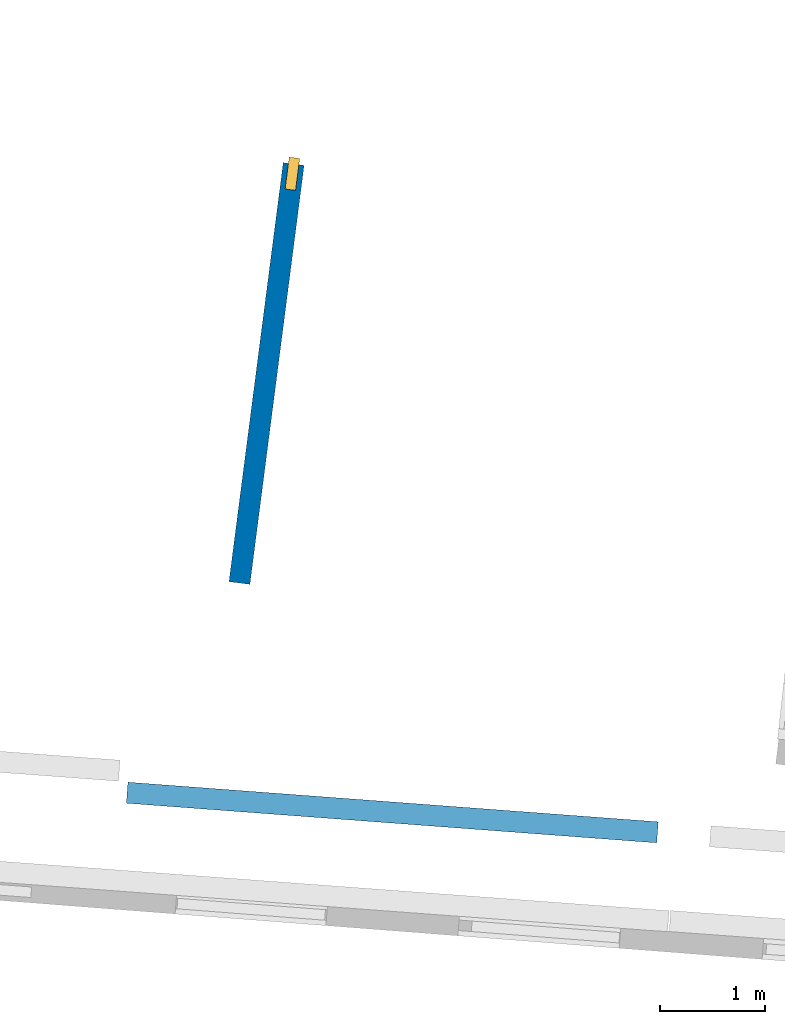
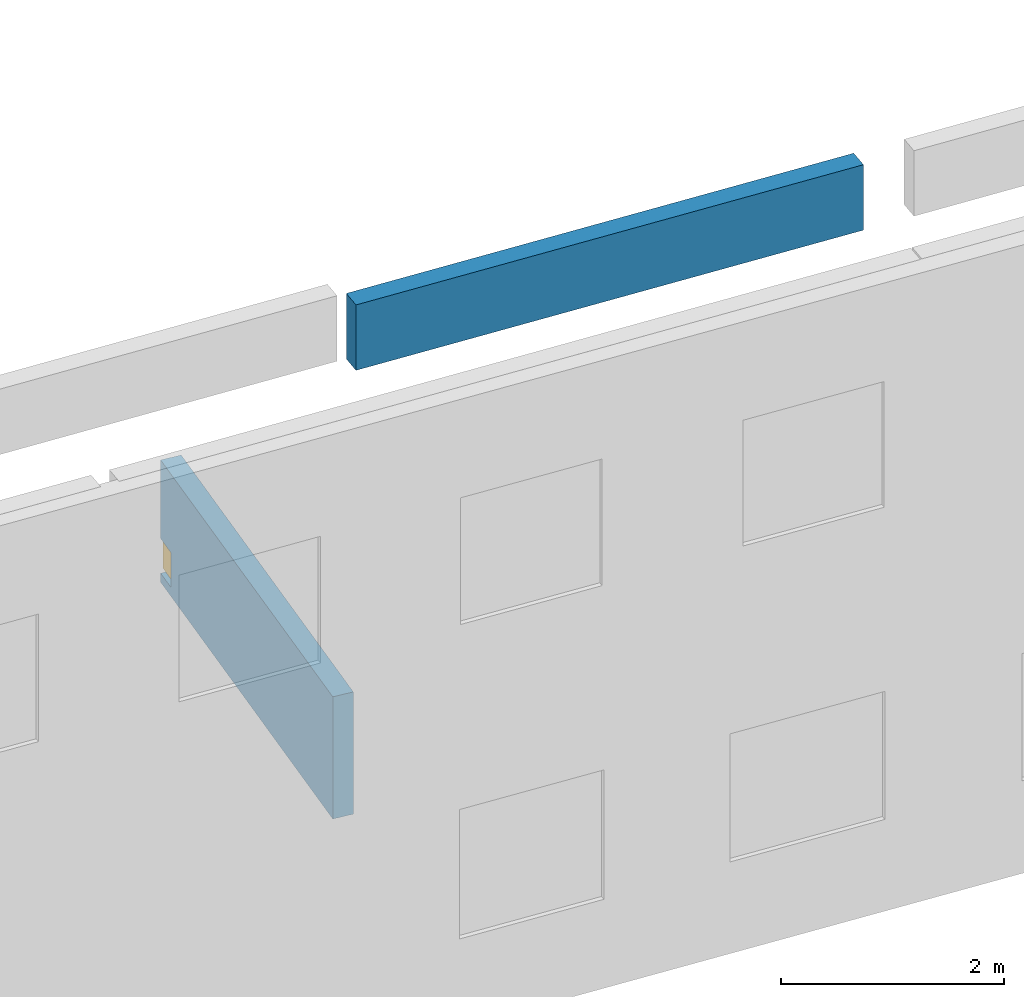
# One storey, part 11 of 27: 2 walls, 1 window, 1 opening.
"""IFC2X3 building model written with IfcOpenShell, lengths in metres."""

from ifc_helpers import new_model, entity, si_unit, converted_unit, derived_unit, direction, frame, frame_2d, origin, origin_2d_with_axis, place, context, subcontext, project, spatial, polyline, rectangle, outline, extrude, source, transform, mapped, material, layer, layer_set, layer_usage, type_object, type_shapes, element, fill, save


model = new_model("IFC2X3")

# Units and contexts
model_context = context("Model", 3, precision=1e-05, world=origin(), true_north=direction((0.0, 1.0)))
body_context = subcontext(model_context, "Body", "Model", "MODEL_VIEW")
ifc_project = project(units=[si_unit("LENGTHUNIT", "METRE"), si_unit("AREAUNIT", "SQUARE_METRE"), si_unit("VOLUMEUNIT", "CUBIC_METRE"), converted_unit("PLANEANGLEUNIT", "DEGREE", entity("IfcRatioMeasure", 0.0174532925199433), si_unit("PLANEANGLEUNIT", "RADIAN"), dimensions=[0, 0, 0, 0, 0, 0, 0]), si_unit("MASSUNIT", "GRAM", prefix="KILO"), derived_unit("MASSDENSITYUNIT", [(si_unit("MASSUNIT", "GRAM", prefix="KILO"), 1), (si_unit("LENGTHUNIT", "METRE"), -3)]), derived_unit("MOMENTOFINERTIAUNIT", [(si_unit("LENGTHUNIT", "METRE"), 4)]), si_unit("TIMEUNIT", "SECOND"), si_unit("FREQUENCYUNIT", "HERTZ"), si_unit("THERMODYNAMICTEMPERATUREUNIT", "DEGREE_CELSIUS"), derived_unit("THERMALTRANSMITTANCEUNIT", [(si_unit("MASSUNIT", "GRAM", prefix="KILO"), 1), (si_unit("THERMODYNAMICTEMPERATUREUNIT", "KELVIN"), -1), (si_unit("TIMEUNIT", "SECOND"), -3)]), derived_unit("VOLUMETRICFLOWRATEUNIT", [(si_unit("LENGTHUNIT", "METRE"), 3), (si_unit("TIMEUNIT", "SECOND"), -1)]), si_unit("ELECTRICCURRENTUNIT", "AMPERE"), si_unit("ELECTRICVOLTAGEUNIT", "VOLT"), si_unit("POWERUNIT", "WATT"), si_unit("FORCEUNIT", "NEWTON", prefix="KILO"), si_unit("ILLUMINANCEUNIT", "LUX"), si_unit("LUMINOUSFLUXUNIT", "LUMEN"), si_unit("LUMINOUSINTENSITYUNIT", "CANDELA"), derived_unit("USERDEFINED", [(si_unit("MASSUNIT", "GRAM", prefix="KILO"), -1), (si_unit("LENGTHUNIT", "METRE"), -2), (si_unit("TIMEUNIT", "SECOND"), 3), (si_unit("LUMINOUSFLUXUNIT", "LUMEN"), 1)]), derived_unit("LINEARVELOCITYUNIT", [(si_unit("LENGTHUNIT", "METRE"), 1), (si_unit("TIMEUNIT", "SECOND"), -1)]), si_unit("PRESSUREUNIT", "PASCAL"), derived_unit("USERDEFINED", [(si_unit("LENGTHUNIT", "METRE"), -2), (si_unit("MASSUNIT", "GRAM", prefix="KILO"), 1), (si_unit("TIMEUNIT", "SECOND"), -2)]), derived_unit("LINEARFORCEUNIT", [(si_unit("MASSUNIT", "GRAM", prefix="KILO"), 1), (si_unit("LENGTHUNIT", "METRE"), 1), (si_unit("TIMEUNIT", "SECOND"), -2), (si_unit("LENGTHUNIT", "METRE"), -1)]), derived_unit("PLANARFORCEUNIT", [(si_unit("MASSUNIT", "GRAM", prefix="KILO"), 1), (si_unit("LENGTHUNIT", "METRE"), 1), (si_unit("TIMEUNIT", "SECOND"), -2), (si_unit("LENGTHUNIT", "METRE"), -2)])], contexts=[model_context])

# Site, building, storey
placement_1 = place(None, origin())
site = spatial("IfcSite", under=ifc_project, at=placement_1, CompositionType="ELEMENT")
building = spatial("IfcBuilding", under=site, at=placement_1, CompositionType="ELEMENT")
storey_placement = place(placement_1, frame((0.0, 0.0, -61.043098449707)))
storey = spatial("IfcBuildingStorey", under=building, at=storey_placement, Name="level_-61.043098", CompositionType="ELEMENT", Elevation=-61.043098449707)

# Wall
ifc_material_1 = material(Name="Default wall")
ifc_layer = layer(ifc_material_1, 0.2)
ifc_layer_set = layer_set([ifc_layer], Name="wall_thickness_0.2000")
ifc_layer_usage = layer_usage(ifc_layer_set, "AXIS2", "POSITIVE", -0.1)
wall_type = type_object("IfcWallType", Name="wall_thickness_0.2000", PredefinedType="STANDARD", material=ifc_layer_set)
placement_2 = place(placement_1, frame((0.0, 0.0, -54.3638687133789)))
wall_1_placement = place(placement_2, frame((-58.0587510180623, 0.415187404365993, 0.0), z_axis=(0.0, 0.0, 1.0), x_axis=(0.997217438638933, -0.0745478374898007, 0.0)))
element("IfcWallStandardCase", 1, at=wall_1_placement, inside=storey, type_object=wall_type, material=ifc_layer_usage, Name="Wall:533", ObjectType="Wall", context=body_context, shape_type="SweptSolid", body=[
    extrude(outline(polyline([(5.04500192512845, -0.1), (5.04500192512845, 0.1), (0.0, 0.1), (0.0, -0.1), (5.04500192512845, -0.1)])), origin(), (0.0, 0.0, 1.0), 0.715465545654297),
])

# Wall, opening, window
placement_3 = place(placement_1, frame((0.0, 0.0, -60.8847198486328)))
wall_2_placement = place(placement_3, frame((-56.9934852443287, 2.40439771442265, 0.0), z_axis=(0.0, 0.0, 1.0), x_axis=(0.128283797372548, 0.991737499206156, 0.0)))
wall_2 = element("IfcWallStandardCase", 2, at=wall_2_placement, inside=storey, type_object=wall_type, material=ifc_layer_usage, Name="Wall:1335", ObjectType="Wall", context=body_context, shape_type="SweptSolid", body=[
    extrude(outline(polyline([(4.00781141965501, -0.1), (4.00781141965501, 0.1), (0.0, 0.1), (0.0, -0.1), (4.00781141965501, -0.1)])), origin(), (0.0, 0.0, 1.0), 1.33630752563477),
])
opening_placement = place(wall_2_placement, frame((3.76217501523748, -0.1, 0.0984268188476562)))
opening = element("IfcOpeningElement", 3, at=opening_placement, cuts=wall_2, Name="Opening : 305 x 380 : 202", ObjectType="Opening", context=body_context, shape_type="SweptSolid", body=[
    extrude(rectangle(XDim=0.305, YDim=0.38, at=frame_2d((0.19, 0.1525), x_axis=(0.0, 1.0))), frame((0.0, 0.0, 0.0), z_axis=(0.0, 1.0, 0.0), x_axis=(0.0, 0.0, 1.0)), (0.0, 0.0, 1.0), 0.2),
])
ifc_material_2 = material(Name="Window Default")
window_style = type_object("IfcWindowStyle", Name="Window : 305 x 380mm", ConstructionType="NOTDEFINED", OperationType="NOTDEFINED", ParameterTakesPrecedence=False, Sizeable=False, material=ifc_material_2)
shared_shape = source(origin(), body_context, "Body", "SweptSolid", [
    extrude(rectangle(XDim=0.1, YDim=0.305, at=origin_2d_with_axis()), frame((0.1525, 0.1, 0.0), z_axis=(0.0, 0.0, 1.0), x_axis=(0.0, 1.0, 0.0)), (0.0, 0.0, 1.0), 0.38),
])
type_shapes(window_style, [shared_shape])
window_placement = place(opening_placement, origin())
window = element("IfcWindow", 4, at=window_placement, inside=storey, type_object=window_style, Name="Window : 305 x 380mm : 185", ObjectType="Window : 305 x 380mm", OverallHeight=0.38, OverallWidth=0.305, context=body_context, shape_type="MappedRepresentation", body=[
    mapped(shared_shape, transform((0.0, 0.0, 0.0), scale=1.0)),
])
fill(opening, window)

save(model, "model.ifc")
